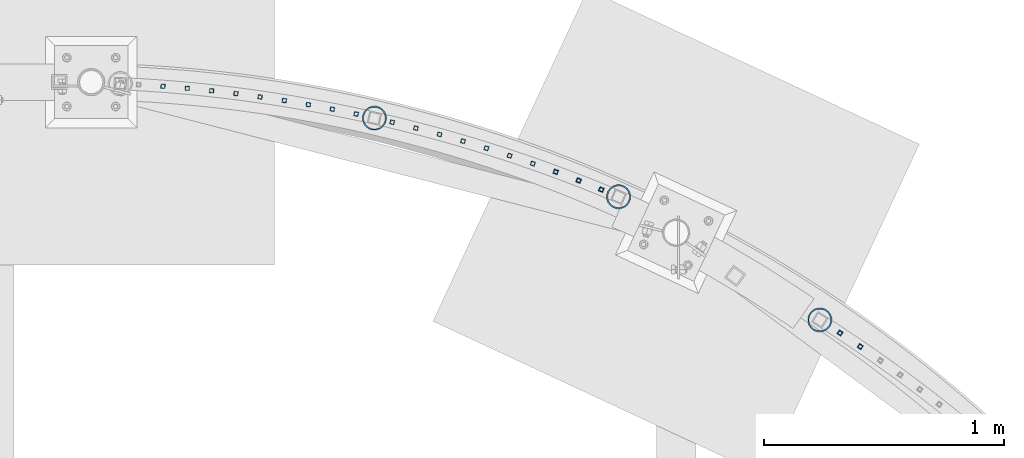
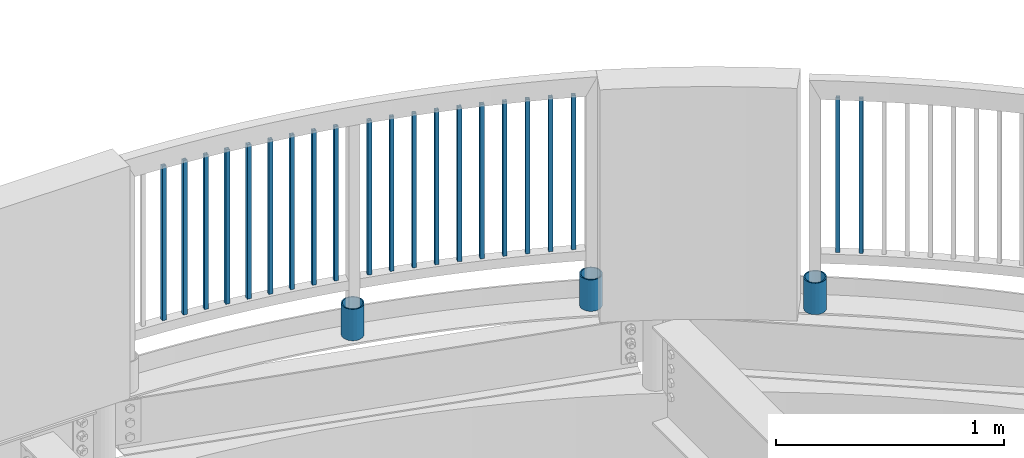
# One storey, part 249 of 975: 24 columns.
"""IFC2X3 building model written with IfcOpenShell, lengths in millimetres."""

from ifc_helpers import new_model, si_unit, frame, origin_with_axes, place, context, subcontext, project, spatial, faceted_brep, material, type_object, element, save


model = new_model("IFC2X3")

# Units and contexts
model_context = context("Model", 3, precision=1e-05, world=origin_with_axes())
body_context = subcontext(model_context, "Body", "Model", "MODEL_VIEW")
ifc_project = project(units=[si_unit("LENGTHUNIT", "METRE", prefix="MILLI"), si_unit("AREAUNIT", "SQUARE_METRE"), si_unit("VOLUMEUNIT", "CUBIC_METRE"), si_unit("MASSUNIT", "GRAM", prefix="KILO"), si_unit("TIMEUNIT", "SECOND"), si_unit("PLANEANGLEUNIT", "RADIAN"), si_unit("SOLIDANGLEUNIT", "STERADIAN"), si_unit("THERMODYNAMICTEMPERATUREUNIT", "DEGREE_CELSIUS"), si_unit("LUMINOUSINTENSITYUNIT", "LUMEN")], contexts=[model_context])

# Site, building, storey
site_placement = place(None, origin_with_axes())
site = spatial("IfcSite", under=ifc_project, at=site_placement, CompositionType="ELEMENT")
building_placement = place(site_placement, origin_with_axes())
building = spatial("IfcBuilding", under=site, at=building_placement, Name="Undefined", CompositionType="ELEMENT")
storey_placement = place(building_placement, origin_with_axes())
storey = spatial("IfcBuildingStorey", under=building, at=storey_placement, Name="Undefined", CompositionType="ELEMENT", Elevation=0.0)

# Columns
ifc_material_1 = material()
column_type_1 = type_object("IfcColumnType", Name="HSS3/4X3/4X.120_TUBES", PredefinedType="NOTDEFINED")
for number, where, z_axis, x_axis, name in (
    (1, (17677.3901865354, 29795.2633294479, 4254.50002056753), (0.23965992689368, 0.970856899569301, -1.43109764394467e-08), (0.0, 0.0, 1.0), "PICKET"),
    (2, (19626.1503111137, 28861.184384995, 4254.50002056753), (0.563205307276902, 0.82631699840626, -1.44214454849134e-08), (0.0, 0.0, 1.0), "PICKET"),
    (3, (19541.850598902, 28917.9400200187, 4254.50002056753), (0.548245395964096, 0.836317514945234, -1.38735267682933e-08), (0.0, 0.0, 1.0), "PICKET"),
    (4, (18547.895266056, 29515.0706764207, 4254.50002056753), (0.370186043931346, 0.928957637827721, -1.39273797685746e-08), (0.0, 0.0, 1.0), "PICKET"),
    (5, (18453.4970306174, 29552.6086471659, 4254.50002056753), (0.354151489929383, 0.935188067813527, -1.3928201951785e-08), (0.0, 0.0, 1.0), "PICKET"),
    (6, (18358.3502807797, 29588.6220918784, 4254.50002056753), (0.337473047123774, 0.941335191345248, -1.3924722225056e-08), (0.0, 0.0, 1.0), "PICKET"),
    (7, (18262.6735667136, 29623.0255079318, 4254.50002056753), (0.322365980142713, 0.946615114419069, -1.48644430737477e-08), (0.0, 0.0, 1.0), "PICKET"),
    (8, (18166.3598970122, 29655.8483164361, 4254.50002056753), (0.305437915071383, 0.952211993222542, -1.45527201311779e-08), (0.0, 0.0, 1.0), "PICKET"),
    (9, (18069.7044138035, 29686.9440754395, 4254.50002056753), (0.287762952986497, 0.957701666955055, -1.45588755913195e-08), (0.0, 0.0, 1.0), "PICKET"),
    (10, (17972.1539867886, 29716.5440361874, 4254.50002056753), (0.269989420897968, 0.962863288636128, -1.45600442920113e-08), (0.0, 0.0, 1.0), "PICKET"),
    (11, (17874.2782189745, 29744.467979439, 4254.50002056753), (0.252123407054532, 0.967695090209315, -1.45562253237585e-08), (0.0, 0.0, 1.0), "PICKET"),
    (12, (17775.97762605, 29770.7208164771, 4254.50002056753), (0.23965992689368, 0.970856899569301, -1.43109764394467e-08), (0.0, 0.0, 1.0), "PICKET"),
    (13, (17527.5418863731, 29829.3175562819, 4254.50002056753), (0.191980890016682, 0.981398664085295, -1.43155239129555e-08), (0.0, 0.0, 1.0), "PICKET"),
    (14, (17427.9786750392, 29849.6270210891, 4254.50002056753), (0.17378520104663, 0.984783582264236, -1.43083261718857e-08), (0.0, 0.0, 1.0), "PICKET"),
    (15, (17328.1310316794, 29868.3348492565, 4254.50002056753), (0.158463871055635, 0.987364776346646, -1.4140035091259e-08), (0.0, 0.0, 1.0), "PICKET"),
    (16, (17227.8813820684, 29885.3723976805, 4254.50002056753), (0.143329854055166, 0.98967497338092, -1.41421096486738e-08), (0.0, 0.0, 1.0), "PICKET"),
    (17, (17127.3569532962, 29900.6990034021, 4254.50002056753), (0.124989327032552, 0.99215808625841, -1.41401924338425e-08), (0.0, 0.0, 1.0), "PICKET"),
    (18, (17026.7181776107, 29914.3336328217, 4254.50002056753), (0.119341932041895, 0.992853213348533, -1.41386290124501e-08), (0.0, 0.0, 1.0), "PICKET"),
    (19, (16925.5438239944, 29926.3278033526, 4254.50002056753), (0.0909442759902633, 0.995855982893413, -1.40329284477048e-08), (0.0, 0.0, 1.0), "PICKET"),
    (20, (16824.2184612224, 29936.5848803505, 4254.50002056753), (0.0635804200166094, 0.997976718260758, -1.40352549351519e-08), (0.0, 0.0, 1.0), "PICKET"),
    (21, (16723.0196866355, 29945.110062361, 4254.50002056753), (0.0635804200166094, 0.997976718260758, -1.40352549351519e-08), (0.0, 0.0, 1.0), "PICKET"),
):
    element("IfcColumn", number, at=place(storey_placement, frame(where, z_axis=z_axis, x_axis=x_axis)), inside=storey, type_object=column_type_1, material=ifc_material_1, Name=name, ObjectType="HSS3/4X3/4X.120_TUBES", context=body_context, shape_type="Brep", body=[
        faceted_brep([(0.0, 6.34999999998763, -6.34999999998763), (0.0, -6.35000000000582, -6.34999999998763), (825.49997943247, -6.35000000000582, -6.34999999998763), (825.49997943247, 6.34999999998763, -6.34999999998763), (0.0, -6.34999999998763, 6.34999999998763), (825.49997943247, -6.34999999998763, 6.34999999998763), (0.0, 6.35000000000946, 6.34999999998763), (825.49997943247, 6.35000000000946, 6.34999999998763), (0.0, 9.52499999997963, -9.52499999997963), (0.0, 9.52500000000873, 9.5249999999869), (825.49997943247, 9.52500000000873, 9.5249999999869), (825.49997943247, 9.52499999997963, -9.52499999997963), (0.0, -9.52499999997963, 9.52499999998327), (825.49997943247, -9.52499999997963, 9.52499999998327), (0.0, -9.52500000000873, -9.5249999999869), (825.49997943247, -9.52500000000873, -9.5249999999869)], [[[0, 1, 2, 3]], [[1, 4, 5, 2]], [[4, 6, 7, 5]], [[6, 0, 3, 7]], [[8, 9, 10, 11]], [[9, 12, 13, 10]], [[12, 14, 15, 13]], [[14, 8, 11, 15]], [[13, 15, 11, 10], [5, 7, 3, 2]], [[14, 12, 9, 8], [6, 4, 1, 0]]]),
    ])
ifc_material_2 = material(Name="STEEL/A53")
column_type_2 = type_object("IfcColumnType", Name="PIPE3-1/2STD", PredefinedType="NOTDEFINED")
column_1_placement = place(storey_placement, frame((19457.7336300041, 28972.1255563363, 3946.525), z_axis=(-0.707106781186601, 0.707106781186494, 2.36468622460961e-14), x_axis=(0.0, 0.0, 1.0)))
element("IfcColumn", 22, at=column_1_placement, inside=storey, type_object=column_type_2, material=ifc_material_2, ObjectType="PIPE3-1/2STD", context=body_context, shape_type="Brep", body=[
    faceted_brep([(0.0, -45.0595999999932, 1.45519152283669e-11), (0.0, -42.8542262016344, 13.924182159768), (168.275, -42.8542262015544, 13.9241821597034), (168.275, -45.0595999998914, 2.72848410531878e-12), (0.0, -36.45398215971, 26.4853683542424), (168.275, -36.4539821596554, 26.485368354136), (0.0, -26.4853683541623, 36.45398215979), (168.275, -26.4853683541369, 36.4539821596509), (0.0, -13.9241821596988, 42.8542262017108), (168.275, -13.9241821597025, 42.8542262015517), (0.0, 3.63797880709171e-11, 45.0596000000514), (168.275, 0.0, 45.0595999998905), (0.0, 13.9241821597716, 42.8542262017036), (168.275, 13.9241821597025, 42.8542262015517), (0.0, 26.4853683542242, 36.4539821597718), (168.275, 26.4853683541296, 36.4539821596509), (0.0, 36.4539821597537, 26.4853683542206), (168.275, 36.4539821596481, 26.4853683541342), (0.0, 42.8542262016563, 13.9241821597425), (168.275, 42.8542262015471, 13.9241821597034), (0.0, 45.0595999999932, -1.09139364212751e-11), (168.275, 45.0595999998914, -9.09494701772928e-13), (0.0, 42.8542262016344, -13.9241821597643), (168.275, 42.8542262015471, -13.9241821596997), (0.0, 36.45398215971, -26.4853683542387), (168.275, 36.4539821596481, -26.4853683541323), (0.0, 26.4853683541623, -36.4539821597864), (168.275, 26.4853683541296, -36.4539821596472), (0.0, 13.9241821596988, -42.8542262017072), (168.275, 13.9241821596952, -42.854226201548), (0.0, -3.63797880709171e-11, -45.0596000000478), (168.275, 0.0, -45.0595999998886), (0.0, -13.9241821597716, -42.8542262016963), (168.275, -13.9241821597025, -42.8542262015499), (0.0, -26.4853683542242, -36.4539821597682), (168.275, -26.4853683541369, -36.4539821596472), (0.0, -36.4539821597537, -26.4853683542169), (168.275, -36.4539821596554, -26.4853683541305), (0.0, -42.8542262016563, -13.9241821597352), (168.275, -42.8542262015544, -13.9241821597016), (0.0, -50.799999999992, 1.81898940354586e-11), (0.0, -48.3136710278013, -15.6980633142484), (168.275, -48.3136710276813, -15.6980633142075), (168.275, -50.7999999998792, 9.09494701772928e-13), (0.0, -41.0980633142644, -29.8594908164741), (168.275, -41.0980633141517, -29.8594908163841), (0.0, -29.859490816485, -41.0980633142826), (168.275, -29.8594908163868, -41.0980633141471), (0.0, -15.6980633142848, -48.313671027845), (168.275, -15.6980633142084, -48.3136710276767), (0.0, -4.36557456851006e-11, -50.8000000000575), (168.275, 0.0, -50.7999999998747), (0.0, 15.6980633142011, -48.3136710278523), (168.275, 15.6980633142084, -48.3136710276749), (0.0, 29.8594908164159, -41.0980633143045), (168.275, 29.8594908163868, -41.0980633141471), (0.0, 41.0980633142135, -29.8594908165032), (168.275, 41.0980633141444, -29.8594908163859), (0.0, 48.3136710277722, -15.6980633142775), (168.275, 48.313671027674, -15.6980633142057), (0.0, 50.799999999992, -1.45519152283669e-11), (168.275, 50.7999999998719, 9.09494701772928e-13), (0.0, 48.313671027794, 15.6980633142521), (168.275, 48.313671027674, 15.6980633142093), (0.0, 41.0980633142644, 29.8594908164814), (168.275, 41.0980633141444, 29.8594908163877), (0.0, 29.859490816485, 41.0980633142863), (168.275, 29.8594908163795, 41.0980633141507), (0.0, 15.6980633142848, 48.3136710278486), (168.275, 15.6980633142084, 48.3136710276785), (0.0, 4.00177668780088e-11, 50.8000000000611), (168.275, 0.0, 50.7999999998765), (0.0, -15.6980633142011, 48.3136710278559), (168.275, -15.6980633142084, 48.3136710276785), (0.0, -29.8594908164159, 41.0980633143081), (168.275, -29.8594908163941, 41.0980633141507), (0.0, -41.0980633142171, 29.8594908165069), (168.275, -41.0980633141517, 29.8594908163896), (0.0, -48.3136710277722, 15.6980633142812), (168.275, -48.3136710276813, 15.6980633142093)], [[[0, 1, 2, 3]], [[1, 4, 5, 2]], [[4, 6, 7, 5]], [[6, 8, 9, 7]], [[8, 10, 11, 9]], [[10, 12, 13, 11]], [[12, 14, 15, 13]], [[14, 16, 17, 15]], [[16, 18, 19, 17]], [[18, 20, 21, 19]], [[20, 22, 23, 21]], [[22, 24, 25, 23]], [[24, 26, 27, 25]], [[26, 28, 29, 27]], [[28, 30, 31, 29]], [[30, 32, 33, 31]], [[32, 34, 35, 33]], [[34, 36, 37, 35]], [[36, 38, 39, 37]], [[38, 0, 3, 39]], [[40, 41, 42, 43]], [[41, 44, 45, 42]], [[44, 46, 47, 45]], [[46, 48, 49, 47]], [[48, 50, 51, 49]], [[50, 52, 53, 51]], [[52, 54, 55, 53]], [[54, 56, 57, 55]], [[56, 58, 59, 57]], [[58, 60, 61, 59]], [[60, 62, 63, 61]], [[62, 64, 65, 63]], [[64, 66, 67, 65]], [[66, 68, 69, 67]], [[68, 70, 71, 69]], [[70, 72, 73, 71]], [[72, 74, 75, 73]], [[74, 76, 77, 75]], [[76, 78, 79, 77]], [[78, 40, 43, 79]], [[45, 47, 49, 51, 53, 55, 57, 59, 61, 63, 65, 67, 69, 71, 73, 75, 77, 79, 43, 42], [5, 7, 9, 11, 13, 15, 17, 19, 21, 23, 25, 27, 29, 31, 33, 35, 37, 39, 3, 2]], [[78, 76, 74, 72, 70, 68, 66, 64, 62, 60, 58, 56, 54, 52, 50, 48, 46, 44, 41, 40], [38, 36, 34, 32, 30, 28, 26, 24, 22, 20, 18, 16, 14, 12, 10, 8, 6, 4, 1, 0]]]),
])
column_2_placement = place(storey_placement, frame((18619.9305050041, 29485.0864943363, 3946.525), z_axis=(-0.707106781186601, 0.707106781186494, 2.36468622460961e-14), x_axis=(0.0, 0.0, 1.0)))
element("IfcColumn", 23, at=column_2_placement, inside=storey, type_object=column_type_2, material=ifc_material_2, ObjectType="PIPE3-1/2STD", context=body_context, shape_type="Brep", body=[
    faceted_brep([(0.0, -45.0595999999932, 1.45519152283669e-11), (0.0, -42.8542262016344, 13.924182159768), (168.275, -42.8542262015544, 13.9241821597034), (168.275, -45.0595999998914, 2.72848410531878e-12), (0.0, -36.45398215971, 26.4853683542424), (168.275, -36.4539821596554, 26.485368354136), (0.0, -26.4853683541623, 36.45398215979), (168.275, -26.4853683541369, 36.4539821596509), (0.0, -13.9241821596988, 42.8542262017108), (168.275, -13.9241821597025, 42.8542262015517), (0.0, 3.63797880709171e-11, 45.0596000000514), (168.275, 0.0, 45.0595999998905), (0.0, 13.9241821597716, 42.8542262017036), (168.275, 13.9241821597025, 42.8542262015517), (0.0, 26.4853683542242, 36.4539821597718), (168.275, 26.4853683541296, 36.4539821596509), (0.0, 36.4539821597537, 26.4853683542206), (168.275, 36.4539821596481, 26.4853683541342), (0.0, 42.8542262016563, 13.9241821597425), (168.275, 42.8542262015471, 13.9241821597034), (0.0, 45.0595999999932, -1.09139364212751e-11), (168.275, 45.0595999998914, -9.09494701772928e-13), (0.0, 42.8542262016344, -13.9241821597643), (168.275, 42.8542262015471, -13.9241821596997), (0.0, 36.45398215971, -26.4853683542387), (168.275, 36.4539821596481, -26.4853683541323), (0.0, 26.4853683541623, -36.4539821597864), (168.275, 26.4853683541296, -36.4539821596472), (0.0, 13.9241821596988, -42.8542262017072), (168.275, 13.9241821596952, -42.854226201548), (0.0, -3.63797880709171e-11, -45.0596000000478), (168.275, 0.0, -45.0595999998886), (0.0, -13.9241821597716, -42.8542262016963), (168.275, -13.9241821597025, -42.8542262015499), (0.0, -26.4853683542242, -36.4539821597682), (168.275, -26.4853683541369, -36.4539821596472), (0.0, -36.4539821597537, -26.4853683542169), (168.275, -36.4539821596554, -26.4853683541305), (0.0, -42.8542262016563, -13.9241821597352), (168.275, -42.8542262015544, -13.9241821597016), (0.0, -50.799999999992, 1.81898940354586e-11), (0.0, -48.3136710278013, -15.6980633142484), (168.275, -48.3136710276813, -15.6980633142075), (168.275, -50.7999999998792, 9.09494701772928e-13), (0.0, -41.0980633142644, -29.8594908164741), (168.275, -41.0980633141517, -29.8594908163841), (0.0, -29.859490816485, -41.0980633142826), (168.275, -29.8594908163868, -41.0980633141471), (0.0, -15.6980633142848, -48.313671027845), (168.275, -15.6980633142084, -48.3136710276767), (0.0, -4.36557456851006e-11, -50.8000000000575), (168.275, 0.0, -50.7999999998747), (0.0, 15.6980633142011, -48.3136710278523), (168.275, 15.6980633142084, -48.3136710276749), (0.0, 29.8594908164159, -41.0980633143045), (168.275, 29.8594908163868, -41.0980633141471), (0.0, 41.0980633142135, -29.8594908165032), (168.275, 41.0980633141444, -29.8594908163859), (0.0, 48.3136710277722, -15.6980633142775), (168.275, 48.313671027674, -15.6980633142057), (0.0, 50.799999999992, -1.45519152283669e-11), (168.275, 50.7999999998719, 9.09494701772928e-13), (0.0, 48.313671027794, 15.6980633142521), (168.275, 48.313671027674, 15.6980633142093), (0.0, 41.0980633142644, 29.8594908164814), (168.275, 41.0980633141444, 29.8594908163877), (0.0, 29.859490816485, 41.0980633142863), (168.275, 29.8594908163795, 41.0980633141507), (0.0, 15.6980633142848, 48.3136710278486), (168.275, 15.6980633142084, 48.3136710276785), (0.0, 4.00177668780088e-11, 50.8000000000611), (168.275, 0.0, 50.7999999998765), (0.0, -15.6980633142011, 48.3136710278559), (168.275, -15.6980633142084, 48.3136710276785), (0.0, -29.8594908164159, 41.0980633143081), (168.275, -29.8594908163941, 41.0980633141507), (0.0, -41.0980633142171, 29.8594908165069), (168.275, -41.0980633141517, 29.8594908163896), (0.0, -48.3136710277722, 15.6980633142812), (168.275, -48.3136710276813, 15.6980633142093)], [[[0, 1, 2, 3]], [[1, 4, 5, 2]], [[4, 6, 7, 5]], [[6, 8, 9, 7]], [[8, 10, 11, 9]], [[10, 12, 13, 11]], [[12, 14, 15, 13]], [[14, 16, 17, 15]], [[16, 18, 19, 17]], [[18, 20, 21, 19]], [[20, 22, 23, 21]], [[22, 24, 25, 23]], [[24, 26, 27, 25]], [[26, 28, 29, 27]], [[28, 30, 31, 29]], [[30, 32, 33, 31]], [[32, 34, 35, 33]], [[34, 36, 37, 35]], [[36, 38, 39, 37]], [[38, 0, 3, 39]], [[40, 41, 42, 43]], [[41, 44, 45, 42]], [[44, 46, 47, 45]], [[46, 48, 49, 47]], [[48, 50, 51, 49]], [[50, 52, 53, 51]], [[52, 54, 55, 53]], [[54, 56, 57, 55]], [[56, 58, 59, 57]], [[58, 60, 61, 59]], [[60, 62, 63, 61]], [[62, 64, 65, 63]], [[64, 66, 67, 65]], [[66, 68, 69, 67]], [[68, 70, 71, 69]], [[70, 72, 73, 71]], [[72, 74, 75, 73]], [[74, 76, 77, 75]], [[76, 78, 79, 77]], [[78, 40, 43, 79]], [[45, 47, 49, 51, 53, 55, 57, 59, 61, 63, 65, 67, 69, 71, 73, 75, 77, 79, 43, 42], [5, 7, 9, 11, 13, 15, 17, 19, 21, 23, 25, 27, 29, 31, 33, 35, 37, 39, 3, 2]], [[78, 76, 74, 72, 70, 68, 66, 64, 62, 60, 58, 56, 54, 52, 50, 48, 46, 44, 41, 40], [38, 36, 34, 32, 30, 28, 26, 24, 22, 20, 18, 16, 14, 12, 10, 8, 6, 4, 1, 0]]]),
])
column_3_placement = place(storey_placement, frame((17603.3351920041, 29812.5083693363, 3946.525), z_axis=(-0.707106781186601, 0.707106781186494, 2.36468622460961e-14), x_axis=(0.0, 0.0, 1.0)))
element("IfcColumn", 24, at=column_3_placement, inside=storey, type_object=column_type_2, material=ifc_material_2, ObjectType="PIPE3-1/2STD", context=body_context, shape_type="Brep", body=[
    faceted_brep([(0.0, -45.0595999999932, 1.45519152283669e-11), (0.0, -42.8542262016344, 13.924182159768), (168.275, -42.8542262015544, 13.9241821597034), (168.275, -45.0595999998914, 2.72848410531878e-12), (0.0, -36.45398215971, 26.4853683542424), (168.275, -36.4539821596554, 26.485368354136), (0.0, -26.4853683541623, 36.45398215979), (168.275, -26.4853683541369, 36.4539821596509), (0.0, -13.9241821596988, 42.8542262017108), (168.275, -13.9241821597025, 42.8542262015517), (0.0, 3.63797880709171e-11, 45.0596000000514), (168.275, 0.0, 45.0595999998905), (0.0, 13.9241821597716, 42.8542262017036), (168.275, 13.9241821597025, 42.8542262015517), (0.0, 26.4853683542242, 36.4539821597718), (168.275, 26.4853683541296, 36.4539821596509), (0.0, 36.4539821597537, 26.4853683542206), (168.275, 36.4539821596481, 26.4853683541342), (0.0, 42.8542262016563, 13.9241821597425), (168.275, 42.8542262015471, 13.9241821597034), (0.0, 45.0595999999932, -1.09139364212751e-11), (168.275, 45.0595999998914, -9.09494701772928e-13), (0.0, 42.8542262016344, -13.9241821597643), (168.275, 42.8542262015471, -13.9241821596997), (0.0, 36.45398215971, -26.4853683542387), (168.275, 36.4539821596481, -26.4853683541323), (0.0, 26.4853683541623, -36.4539821597864), (168.275, 26.4853683541296, -36.4539821596472), (0.0, 13.9241821596988, -42.8542262017072), (168.275, 13.9241821596952, -42.854226201548), (0.0, -3.63797880709171e-11, -45.0596000000478), (168.275, 0.0, -45.0595999998886), (0.0, -13.9241821597716, -42.8542262016963), (168.275, -13.9241821597025, -42.8542262015499), (0.0, -26.4853683542242, -36.4539821597682), (168.275, -26.4853683541369, -36.4539821596472), (0.0, -36.4539821597537, -26.4853683542169), (168.275, -36.4539821596554, -26.4853683541305), (0.0, -42.8542262016563, -13.9241821597352), (168.275, -42.8542262015544, -13.9241821597016), (0.0, -50.799999999992, 1.81898940354586e-11), (0.0, -48.3136710278013, -15.6980633142484), (168.275, -48.3136710276813, -15.6980633142075), (168.275, -50.7999999998792, 9.09494701772928e-13), (0.0, -41.0980633142644, -29.8594908164741), (168.275, -41.0980633141517, -29.8594908163841), (0.0, -29.859490816485, -41.0980633142826), (168.275, -29.8594908163868, -41.0980633141471), (0.0, -15.6980633142848, -48.313671027845), (168.275, -15.6980633142084, -48.3136710276767), (0.0, -4.36557456851006e-11, -50.8000000000575), (168.275, 0.0, -50.7999999998747), (0.0, 15.6980633142011, -48.3136710278523), (168.275, 15.6980633142084, -48.3136710276749), (0.0, 29.8594908164159, -41.0980633143045), (168.275, 29.8594908163868, -41.0980633141471), (0.0, 41.0980633142135, -29.8594908165032), (168.275, 41.0980633141444, -29.8594908163859), (0.0, 48.3136710277722, -15.6980633142775), (168.275, 48.313671027674, -15.6980633142057), (0.0, 50.799999999992, -1.45519152283669e-11), (168.275, 50.7999999998719, 9.09494701772928e-13), (0.0, 48.313671027794, 15.6980633142521), (168.275, 48.313671027674, 15.6980633142093), (0.0, 41.0980633142644, 29.8594908164814), (168.275, 41.0980633141444, 29.8594908163877), (0.0, 29.859490816485, 41.0980633142863), (168.275, 29.8594908163795, 41.0980633141507), (0.0, 15.6980633142848, 48.3136710278486), (168.275, 15.6980633142084, 48.3136710276785), (0.0, 4.00177668780088e-11, 50.8000000000611), (168.275, 0.0, 50.7999999998765), (0.0, -15.6980633142011, 48.3136710278559), (168.275, -15.6980633142084, 48.3136710276785), (0.0, -29.8594908164159, 41.0980633143081), (168.275, -29.8594908163941, 41.0980633141507), (0.0, -41.0980633142171, 29.8594908165069), (168.275, -41.0980633141517, 29.8594908163896), (0.0, -48.3136710277722, 15.6980633142812), (168.275, -48.3136710276813, 15.6980633142093)], [[[0, 1, 2, 3]], [[1, 4, 5, 2]], [[4, 6, 7, 5]], [[6, 8, 9, 7]], [[8, 10, 11, 9]], [[10, 12, 13, 11]], [[12, 14, 15, 13]], [[14, 16, 17, 15]], [[16, 18, 19, 17]], [[18, 20, 21, 19]], [[20, 22, 23, 21]], [[22, 24, 25, 23]], [[24, 26, 27, 25]], [[26, 28, 29, 27]], [[28, 30, 31, 29]], [[30, 32, 33, 31]], [[32, 34, 35, 33]], [[34, 36, 37, 35]], [[36, 38, 39, 37]], [[38, 0, 3, 39]], [[40, 41, 42, 43]], [[41, 44, 45, 42]], [[44, 46, 47, 45]], [[46, 48, 49, 47]], [[48, 50, 51, 49]], [[50, 52, 53, 51]], [[52, 54, 55, 53]], [[54, 56, 57, 55]], [[56, 58, 59, 57]], [[58, 60, 61, 59]], [[60, 62, 63, 61]], [[62, 64, 65, 63]], [[64, 66, 67, 65]], [[66, 68, 69, 67]], [[68, 70, 71, 69]], [[70, 72, 73, 71]], [[72, 74, 75, 73]], [[74, 76, 77, 75]], [[76, 78, 79, 77]], [[78, 40, 43, 79]], [[45, 47, 49, 51, 53, 55, 57, 59, 61, 63, 65, 67, 69, 71, 73, 75, 77, 79, 43, 42], [5, 7, 9, 11, 13, 15, 17, 19, 21, 23, 25, 27, 29, 31, 33, 35, 37, 39, 3, 2]], [[78, 76, 74, 72, 70, 68, 66, 64, 62, 60, 58, 56, 54, 52, 50, 48, 46, 44, 41, 40], [38, 36, 34, 32, 30, 28, 26, 24, 22, 20, 18, 16, 14, 12, 10, 8, 6, 4, 1, 0]]]),
])

save(model, "model.ifc")
